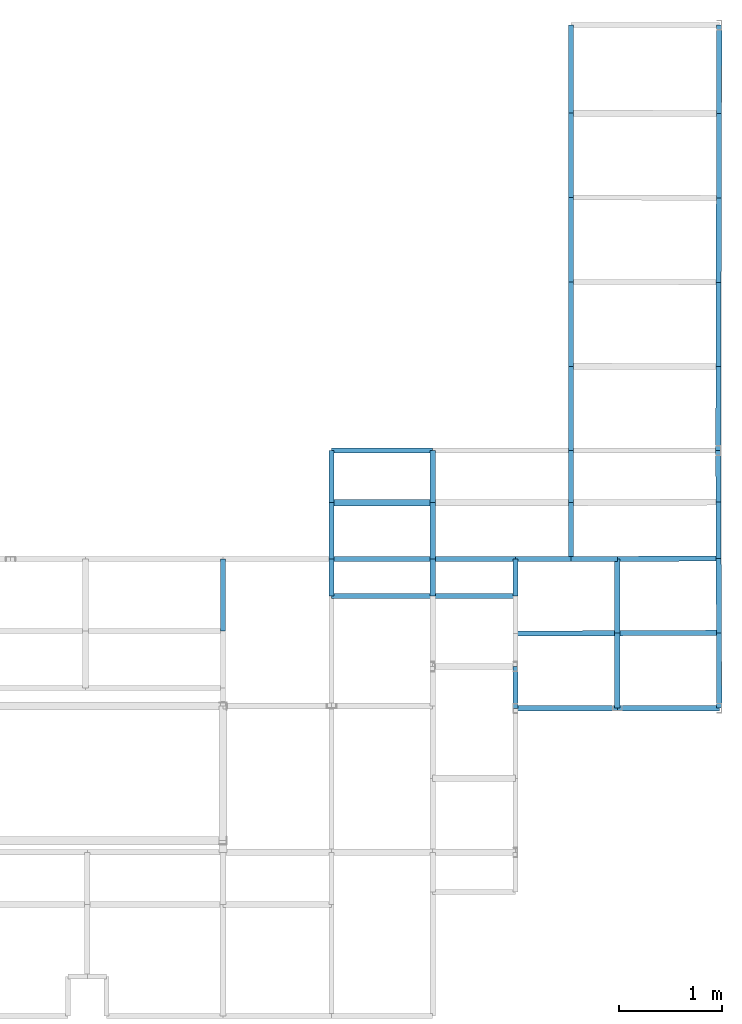
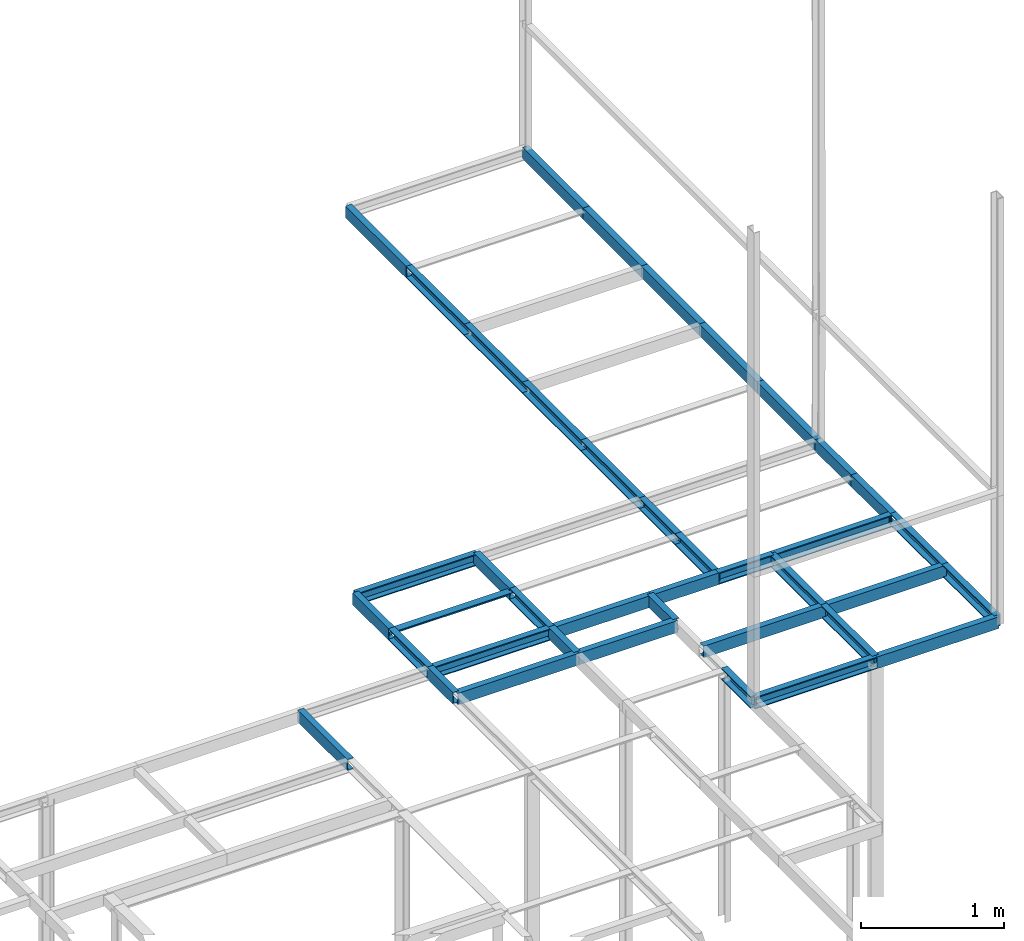
# Not in any storey, part 7 of 7: 40 beams.
"""IFC2X3 model written with IfcOpenShell, lengths in centimetres."""

import ifcopenshell
import ifcopenshell.guid

model = None  # the IFC model being written
_history = None  # IfcOwnerHistory: only IFC2X3 demands one
_inside = {}  # id of a spatial element -> (the spatial element, [elements in it])
_under = {}  # id of a project, library or spatial element -> (it, [spatial elements below it])
_declared = {}  # id of a project -> (the project, [libraries it declares])
_typed = {}  # id of a type object -> (the type object, [elements of that type])
_made_of = {}  # id of a material, layer set ... -> (it, [elements and type objects made of it])


def new_model(schema):
    """Start an empty IFC model of exactly this schema.

    Asked for "IFC4X3", IfcOpenShell would pick the latest addendum, in which some entities
    have other attributes; the version numbers below select the first issue.
    IFC2X3 requires an IfcOwnerHistory on every rooted entity: one is made here for all.
    """
    global model, _history
    if schema == "IFC4X3":
        model = ifcopenshell.file(schema_version=(4, 3, 0, 0))
    else:
        model = ifcopenshell.file(schema=schema)
    _inside.clear()
    _under.clear()
    _declared.clear()
    _typed.clear()
    _made_of.clear()
    _history = None
    if model.schema == "IFC2X3":
        org = make("IfcOrganization", Name="unknown")
        user = make(
            "IfcPersonAndOrganization",
            ThePerson=make("IfcPerson", FamilyName="unknown"),
            TheOrganization=org,
        )
        app = make(
            "IfcApplication",
            ApplicationDeveloper=org,
            Version="unknown",
            ApplicationFullName="unknown",
            ApplicationIdentifier="unknown",
        )
        _history = make(
            "IfcOwnerHistory",
            OwningUser=user,
            OwningApplication=app,
            ChangeAction="ADDED",
            CreationDate=0,
        )
    return model


def make(cls, **values):
    """One entity of the class cls with the attributes given. An attribute that is None is left unset."""
    return model.create_entity(
        cls, **{name: value for name, value in values.items() if value is not None}
    )


def rooted(cls, **values):
    """An entity with a GlobalId (a new one), such as an element, a storey or a relation."""
    return make(cls, GlobalId=ifcopenshell.guid.new(), OwnerHistory=_history, **values)


def si_unit(unit_type, name, prefix=None):
    """IfcSIUnit, for example si_unit("LENGTHUNIT", "METRE", prefix="MILLI")."""
    return make("IfcSIUnit", UnitType=unit_type, Prefix=prefix, Name=name)


def assignment(units):
    """IfcUnitAssignment: the units of a project."""
    return None if units is None else make("IfcUnitAssignment", Units=units)


def point(xyz):
    """IfcCartesianPoint."""
    return None if xyz is None else make("IfcCartesianPoint", Coordinates=xyz)


def direction(xyz):
    """IfcDirection."""
    return None if xyz is None else make("IfcDirection", DirectionRatios=xyz)


def frame(location, z_axis=None, x_axis=None):
    """IfcAxis2Placement3D, a coordinate frame: its origin and axes. An axis left out is left unset."""
    return make(
        "IfcAxis2Placement3D",
        Location=point(location),
        Axis=direction(z_axis),
        RefDirection=direction(x_axis),
    )


def frame_2d(location, x_axis=None):
    """IfcAxis2Placement2D, a coordinate frame in the plane: its origin and x axis."""
    return make(
        "IfcAxis2Placement2D", Location=point(location), RefDirection=direction(x_axis)
    )


def origin_with_axes():
    """The frame at (0, 0, 0) with the z axis (0, 0, 1) and the x axis (1, 0, 0) written out."""
    return frame((0.0, 0.0, 0.0), z_axis=(0.0, 0.0, 1.0), x_axis=(1.0, 0.0, 0.0))


def origin_2d_with_axis():
    """The frame at (0, 0) in the plane with the x axis (1, 0) written out."""
    return frame_2d((0.0, 0.0), x_axis=(1.0, 0.0))


def place(relative_to, where):
    """IfcLocalPlacement: puts the frame where relative to a parent placement (None: the world)."""
    return make(
        "IfcLocalPlacement", PlacementRelTo=relative_to, RelativePlacement=where
    )


def context(
    kind, dimensions, precision=None, world=None, true_north=None, identifier=None
):
    """IfcGeometricRepresentationContext, for example the 3D "Model" context."""
    return make(
        "IfcGeometricRepresentationContext",
        ContextIdentifier=identifier,
        ContextType=kind,
        CoordinateSpaceDimension=dimensions,
        Precision=precision,
        WorldCoordinateSystem=world,
        TrueNorth=true_north,
    )


def project(units=None, contexts=None):
    """IfcProject with its units and contexts."""
    return rooted(
        "IfcProject",
        Name="project",
        RepresentationContexts=contexts,
        UnitsInContext=assignment(units),
    )


def polyline(points):
    """IfcPolyline through the points."""
    return make("IfcPolyline", Points=[point(p) for p in points])


def profile(cls, at=None, kind="AREA", **sizes):
    """A parametric profile (cls). Its sizes go by their IFC names, for example OverallWidth=200.0."""
    return make(cls, ProfileType=kind, Position=at, **sizes)


def u_section(**sizes):
    """IfcUShapeProfileDef."""
    return profile("IfcUShapeProfileDef", **sizes)


def outline(outer, holes=None, kind="AREA"):
    """IfcArbitraryClosedProfileDef: a profile drawn as a closed curve; with holes, ...WithVoids."""
    if holes is None:
        return make("IfcArbitraryClosedProfileDef", ProfileType=kind, OuterCurve=outer)
    return make(
        "IfcArbitraryProfileDefWithVoids",
        ProfileType=kind,
        OuterCurve=outer,
        InnerCurves=holes,
    )


def extrude(swept, where, along, depth):
    """IfcExtrudedAreaSolid: the profile swept, set in the frame where, extruded along a direction by depth."""
    return make(
        "IfcExtrudedAreaSolid",
        SweptArea=swept,
        Position=where,
        ExtrudedDirection=direction(along),
        Depth=depth,
    )


def shape(context_of_items, identifier, shape_type, items):
    """IfcShapeRepresentation: the items that make up one representation, for example the "Body"."""
    return make(
        "IfcShapeRepresentation",
        ContextOfItems=context_of_items,
        RepresentationIdentifier=identifier,
        RepresentationType=shape_type,
        Items=items,
    )


def material(Name=None, Category=None):
    """IfcMaterial."""
    return make("IfcMaterial", Name=Name, Category=Category)


def made_of(thing, what):
    """Note that an element or type object is made of a material, layer set ...; save() writes the relation."""
    if what is not None:
        _made_of.setdefault(what.id(), (what, []))[1].append(thing)
    return thing


def element(
    cls,
    number,
    at=None,
    inside=None,
    cuts=None,
    type_object=None,
    material=None,
    context=None,
    identifier="Body",
    shape_type=None,
    held_by="IfcProductDefinitionShape",
    body=None,
    shapes=None,
    **own,
):
    """One element of the class cls, such as IfcWall. Its Tag is "e" and its number.

    at: its placement. inside: the storey or other place that contains it. cuts: it is an
    opening in that element (IfcRelVoidsElement). A single representation is given by context,
    identifier, shape_type and body (its items); several are given by shapes. held_by: the class
    of the entity that holds the representations. save() writes the other relations.
    """
    e = rooted(cls, Tag="e%d" % number, ObjectPlacement=at, **own)
    if body is not None:
        shapes = [shape(context, identifier, shape_type, body)]
    if shapes is not None:
        e.Representation = make(held_by, Representations=shapes)
    if inside is not None:
        _inside.setdefault(inside.id(), (inside, []))[1].append(e)
    if cuts is not None:
        rooted(
            "IfcRelVoidsElement", RelatingBuildingElement=cuts, RelatedOpeningElement=e
        )
    if type_object is not None:
        _typed.setdefault(type_object.id(), (type_object, []))[1].append(e)
    return made_of(e, material)


def aggregate(whole, parts):
    """IfcRelAggregates: a whole, such as a stair, and the parts it consists of."""
    return rooted("IfcRelAggregates", RelatingObject=whole, RelatedObjects=parts)


def save(model, path):
    """Write the relations noted so far, then the file.

    IfcRelAggregates (storeys below a building ...), IfcRelContainedInSpatialStructure (elements
    in a storey), IfcRelDefinesByType, IfcRelAssociatesMaterial and IfcRelDeclares: one each for
    every whole, place, type object, material and project.
    """
    for whole, parts in _under.values():
        aggregate(whole, parts)
    for where, things in _inside.values():
        rooted(
            "IfcRelContainedInSpatialStructure",
            RelatedElements=things,
            RelatingStructure=where,
        )
    for kind, things in _typed.values():
        rooted("IfcRelDefinesByType", RelatedObjects=things, RelatingType=kind)
    for what, things in _made_of.values():
        rooted("IfcRelAssociatesMaterial", RelatedObjects=things, RelatingMaterial=what)
    for by, libraries in _declared.values():
        rooted("IfcRelDeclares", RelatingContext=by, RelatedDefinitions=libraries)
    model.write(path)


model = new_model("IFC2X3")

# Units and contexts
model_context = context("Model", 3, precision=1e-05, world=origin_with_axes())
plan_context = context("Plan", 3, precision=1e-05, world=origin_with_axes())
ifc_project = project(units=[si_unit("LENGTHUNIT", "METRE", prefix="CENTI"), si_unit("AREAUNIT", "SQUARE_METRE", prefix="CENTI"), si_unit("VOLUMEUNIT", "CUBIC_METRE", prefix="CENTI"), si_unit("PLANEANGLEUNIT", "RADIAN"), si_unit("SOLIDANGLEUNIT", "STERADIAN"), si_unit("MASSUNIT", "GRAM"), si_unit("TIMEUNIT", "SECOND"), si_unit("THERMODYNAMICTEMPERATUREUNIT", "DEGREE_CELSIUS"), si_unit("LUMINOUSINTENSITYUNIT", "LUMEN")], contexts=[model_context, plan_context])

# Beams
ifc_material = material()
beam_1_placement = place(None, frame((345.100006103516, 706.5, 210.0), z_axis=(0.0, 1.0, 0.0), x_axis=(1.0, 0.0, 0.0)))
element("IfcBeam", 1, at=beam_1_placement, material=ifc_material, Name="UPN - de ala UPN 100", context=model_context, shape_type="SweptSolid", body=[
    extrude(u_section(Depth=10.0, FlangeWidth=5.0, WebThickness=0.6, FlangeThickness=0.85, FilletRadius=0.0, EdgeRadius=0.0, FlangeSlope=0.0, CentreOfGravityInX=0.0, at=origin_2d_with_axis()), origin_with_axes(), (0.0, 0.0, 1.0), 85.200012207031),
])
beam_2_placement = place(None, frame((488.300018310547, 706.200012207031, 210.0), z_axis=(0.00233896073, 0.999997264628, 0.0), x_axis=(0.999997258186, -0.002338960767, 0.0)))
element("IfcBeam", 2, at=beam_2_placement, material=ifc_material, Name="UPN - de ala UPN 100", context=model_context, shape_type="SweptSolid", body=[
    extrude(u_section(Depth=10.0, FlangeWidth=5.0, WebThickness=0.6, FlangeThickness=0.85, FilletRadius=0.0, EdgeRadius=0.0, FlangeSlope=0.0, CentreOfGravityInX=0.0, at=frame_2d((-4.42e-09, 0.0), x_axis=(1.0, 0.0))), origin_with_axes(), (0.0, 0.0, 1.0), 85.500233874979),
])
beam_3_placement = place(None, frame((345.100006103516, 624.900024414062, 210.0), z_axis=(0.0, 1.0, 0.0), x_axis=(-1.0, 0.0, 0.0)))
element("IfcBeam", 3, at=beam_3_placement, material=ifc_material, Name="UPN - de ala UPN 100", context=model_context, shape_type="SweptSolid", body=[
    extrude(u_section(Depth=10.0, FlangeWidth=5.0, WebThickness=0.6, FlangeThickness=0.85, FilletRadius=0.0, EdgeRadius=0.0, FlangeSlope=0.0, CentreOfGravityInX=0.0, at=origin_2d_with_axis()), origin_with_axes(), (0.0, 0.0, 1.0), 81.599975585938),
])
beam_4_placement = place(None, frame((488.100006103516, 624.5, 210.0), z_axis=(0.002448122127, 0.999997003345, 0.0), x_axis=(0.999997019768, -0.002448122017, 0.0)))
element("IfcBeam", 4, at=beam_4_placement, material=ifc_material, Name="UPN - de ala UPN 100", context=model_context, shape_type="SweptSolid", body=[
    extrude(u_section(Depth=10.0, FlangeWidth=5.0, WebThickness=0.6, FlangeThickness=0.85, FilletRadius=0.0, EdgeRadius=0.0, FlangeSlope=0.0, CentreOfGravityInX=0.0, at=frame_2d((1.2268e-08, 0.0), x_axis=(1.0, 0.0))), origin_with_axes(), (0.0, 0.0, 1.0), 81.700257034553),
])
beam_5_placement = place(None, frame((345.100006103516, 543.200012207031, 210.0), z_axis=(0.0, 1.0, 0.0), x_axis=(-1.0, 0.0, 0.0)))
element("IfcBeam", 5, at=beam_5_placement, material=ifc_material, Name="UPN - de ala UPN 100", context=model_context, shape_type="SweptSolid", body=[
    extrude(u_section(Depth=10.0, FlangeWidth=5.0, WebThickness=0.6, FlangeThickness=0.85, FilletRadius=0.0, EdgeRadius=0.0, FlangeSlope=0.0, CentreOfGravityInX=0.0, at=origin_2d_with_axis()), origin_with_axes(), (0.0, 0.0, 1.0), 81.700012207031),
])
beam_6_placement = place(None, frame((487.899993896484, 542.799987792969, 210.0), z_axis=(0.002448122127, 0.999997003345, 0.0), x_axis=(0.999997019768, -0.002448122017, 0.0)))
element("IfcBeam", 6, at=beam_6_placement, material=ifc_material, Name="UPN - de ala UPN 100", context=model_context, shape_type="SweptSolid", body=[
    extrude(u_section(Depth=10.0, FlangeWidth=5.0, WebThickness=0.6, FlangeThickness=0.85, FilletRadius=0.0, EdgeRadius=0.0, FlangeSlope=0.0, CentreOfGravityInX=0.0, at=frame_2d((1.2268e-08, 0.0), x_axis=(1.0, 0.0))), origin_with_axes(), (0.0, 0.0, 1.0), 81.700257034553),
])
beam_7_placement = place(None, frame((345.100006103516, 461.5, 210.0), z_axis=(0.0, 1.0, 0.0), x_axis=(-1.0, 0.0, 0.0)))
element("IfcBeam", 7, at=beam_7_placement, material=ifc_material, Name="UPN - de ala UPN 100", context=model_context, shape_type="SweptSolid", body=[
    extrude(u_section(Depth=10.0, FlangeWidth=5.0, WebThickness=0.6, FlangeThickness=0.85, FilletRadius=0.0, EdgeRadius=0.0, FlangeSlope=0.0, CentreOfGravityInX=0.0, at=origin_2d_with_axis()), origin_with_axes(), (0.0, 0.0, 1.0), 81.700012207031),
])
beam_8_placement = place(None, frame((487.700012207031, 461.200012207031, 210.0), z_axis=(0.002450749372, 0.999996996909, 0.0), x_axis=(0.999997019768, -0.002450749278, 0.0)))
element("IfcBeam", 8, at=beam_8_placement, material=ifc_material, Name="UPN - de ala UPN 100", context=model_context, shape_type="SweptSolid", body=[
    extrude(u_section(Depth=10.0, FlangeWidth=5.0, WebThickness=0.6, FlangeThickness=0.85, FilletRadius=0.0, EdgeRadius=0.0, FlangeSlope=0.0, CentreOfGravityInX=0.0, at=frame_2d((1.2204e-08, 0.0), x_axis=(1.0, 0.0))), origin_with_axes(), (0.0, 0.0, 1.0), 81.600220638805),
])
beam_9_placement = place(None, frame((345.100006103516, 379.800018310547, 210.0), z_axis=(0.0, 1.0, 0.0), x_axis=(-1.0, 0.0, 0.0)))
element("IfcBeam", 9, at=beam_9_placement, material=ifc_material, Name="UPN - de ala UPN 100", context=model_context, shape_type="SweptSolid", body=[
    extrude(u_section(Depth=10.0, FlangeWidth=5.0, WebThickness=0.6, FlangeThickness=0.85, FilletRadius=0.0, EdgeRadius=0.0, FlangeSlope=0.0, CentreOfGravityInX=0.0, at=origin_2d_with_axis()), origin_with_axes(), (0.0, 0.0, 1.0), 81.699981689453),
])
beam_10_placement = place(None, frame((487.5, 379.800018310547, 210.0), z_axis=(0.002457145187, 0.999996981214, 0.0), x_axis=(0.999996960163, -0.002457145136, 0.0)))
element("IfcBeam", 10, at=beam_10_placement, material=ifc_material, Name="UPN - de ala UPN 100", context=model_context, shape_type="SweptSolid", body=[
    extrude(u_section(Depth=10.0, FlangeWidth=5.0, WebThickness=0.6, FlangeThickness=0.85, FilletRadius=0.0, EdgeRadius=0.0, FlangeSlope=0.0, CentreOfGravityInX=0.0, at=frame_2d((-3.4e-11, 0.0), x_axis=(1.0, 0.0))), origin_with_axes(), (0.0, 0.0, 1.0), 81.400239626371),
])
beam_11_placement = place(None, frame((211.100006103516, 379.800018310547, 210.0), z_axis=(-1.0, 0.0, 0.0), x_axis=(0.0, -1.0, 0.0)))
element("IfcBeam", 11, at=beam_11_placement, material=ifc_material, Name="UPN - de ala UPN 100", context=model_context, shape_type="SweptSolid", body=[
    extrude(u_section(Depth=10.0, FlangeWidth=5.0, WebThickness=0.6, FlangeThickness=0.85, FilletRadius=0.0, EdgeRadius=0.0, FlangeSlope=0.0, CentreOfGravityInX=0.0, at=origin_2d_with_axis()), origin_with_axes(), (0.0, 0.0, 1.0), 98.000007629395),
])
for number, where, z_axis, x_axis, name in (
    (12, (113.099998474121, 329.399993896484, 210.0), (0.0, 1.0, 0.0), (1.0, 0.0, 0.0), "UPN - de ala UPN 100"),
    (13, (211.100006103516, 329.399993896484, 210.0), (0.0, 1.0, 0.0), (1.0, 0.0, 0.0), "UPN - de ala UPN 100"),
    (14, (345.100006103516, 329.399993896484, 210.0), (0.0, 1.0, 0.0), (-1.0, 0.0, 0.0), "UPN - de ala UPN 100"),
):
    element("IfcBeam", number, at=place(None, frame(where, z_axis=z_axis, x_axis=x_axis)), material=ifc_material, Name=name, context=model_context, shape_type="SweptSolid", body=[
        extrude(u_section(Depth=10.0, FlangeWidth=5.0, WebThickness=0.6, FlangeThickness=0.85, FilletRadius=0.0, EdgeRadius=0.0, FlangeSlope=0.0, CentreOfGravityInX=0.0, at=origin_2d_with_axis()), origin_with_axes(), (0.0, 0.0, 1.0), 50.400024414062),
    ])
beam_12_placement = place(None, frame((487.700012207031, 330.0, 210.0), z_axis=(-0.004016275509, 0.999991934733, 0.0), x_axis=(0.999991953373, 0.004016275518, 0.0)))
element("IfcBeam", 15, at=beam_12_placement, material=ifc_material, Name="UPN - de ala UPN 100", context=model_context, shape_type="SweptSolid", body=[
    extrude(u_section(Depth=10.0, FlangeWidth=5.0, WebThickness=0.6, FlangeThickness=0.85, FilletRadius=0.0, EdgeRadius=0.0, FlangeSlope=0.0, CentreOfGravityInX=0.0, at=frame_2d((-3.289e-09, 0.0), x_axis=(1.0, 0.0))), origin_with_axes(), (0.0, 0.0, 1.0), 49.800419964231),
])
beam_13_placement = place(None, frame((487.899993896484, 275.399993896484, 210.0), z_axis=(-0.003662643328, 0.999993292499, 0.0), x_axis=(0.999993264675, 0.003662643256, 0.0)))
element("IfcBeam", 16, at=beam_13_placement, material=ifc_material, Name="UPN - de ala UPN 100", context=model_context, shape_type="SweptSolid", body=[
    extrude(u_section(Depth=10.0, FlangeWidth=5.0, WebThickness=0.6, FlangeThickness=0.85, FilletRadius=0.0, EdgeRadius=0.0, FlangeSlope=0.0, CentreOfGravityInX=0.0, at=frame_2d((1.603e-09, 0.0), x_axis=(1.0, 0.0))), origin_with_axes(), (0.0, 0.0, 1.0), 54.600372335544),
])
beam_14_placement = place(None, frame((211.100006103516, 329.399993896484, 210.0), z_axis=(-1.0, 0.0, 0.0), x_axis=(0.0, 0.0, 1.0)))
element("IfcBeam", 17, at=beam_14_placement, material=ifc_material, context=model_context, shape_type="SweptSolid", body=[
    extrude(outline(polyline([(3.0, -3.0), (3.0, 3.0), (-3.0, 3.0), (-3.0, 2.5), (2.5, 2.5), (2.5, -3.0), (3.0, -3.0)])), origin_with_axes(), (0.0, 0.0, 1.0), 98.000007629395),
])
for number, where, z_axis, x_axis, name in (
    (18, (113.099998474121, 275.0, 210.0), (0.0, 1.0, 0.0), (-1.0, 0.0, 0.0), "UPN - de ala UPN 100"),
    (19, (211.100006103516, 275.0, 210.0), (0.0, 1.0, 0.0), (-1.0, 0.0, 0.0), "UPN - de ala UPN 100"),
    (20, (345.100006103516, 275.0, 210.0), (0.0, 1.0, 0.0), (-1.0, 0.0, 0.0), "UPN - de ala UPN 100"),
):
    element("IfcBeam", number, at=place(None, frame(where, z_axis=z_axis, x_axis=x_axis)), material=ifc_material, Name=name, context=model_context, shape_type="SweptSolid", body=[
        extrude(u_section(Depth=10.0, FlangeWidth=5.0, WebThickness=0.6, FlangeThickness=0.85, FilletRadius=0.0, EdgeRadius=0.0, FlangeSlope=0.0, CentreOfGravityInX=0.0, at=origin_2d_with_axis()), origin_with_axes(), (0.0, 0.0, 1.0), 54.399993896484),
    ])
beam_15_placement = place(None, frame((389.800018310547, 275.0, 210.0), z_axis=(0.999991687464, 0.004077376871, 0.0), x_axis=(0.004077376798, -0.999991714954, 0.0)))
element("IfcBeam", 21, at=beam_15_placement, material=ifc_material, Name="UPN - de ala UPN 100", context=model_context, shape_type="SweptSolid", body=[
    extrude(u_section(Depth=10.0, FlangeWidth=5.0, WebThickness=0.6, FlangeThickness=0.85, FilletRadius=0.0, EdgeRadius=0.0, FlangeSlope=0.0, CentreOfGravityInX=0.0, at=frame_2d((-1.8198e-08, 0.0), x_axis=(1.0, 0.0))), origin_with_axes(), (0.0, 0.0, 1.0), 98.100791052258),
])
beam_16_placement = place(None, frame((488.200012207031, 203.5, 210.0), z_axis=(-0.004172680447, 0.999991294331, 0.0), x_axis=(-0.999991297722, -0.004172680434, 0.0)))
element("IfcBeam", 22, at=beam_16_placement, material=ifc_material, Name="UPN - de ala UPN 100", context=model_context, shape_type="SweptSolid", body=[
    extrude(u_section(Depth=10.0, FlangeWidth=5.0, WebThickness=0.6, FlangeThickness=0.85, FilletRadius=0.0, EdgeRadius=0.0, FlangeSlope=0.0, CentreOfGravityInX=0.0, at=frame_2d((1.979e-09, 0.0), x_axis=(1.0, 0.0))), origin_with_axes(), (0.0, 0.0, 1.0), 71.900619839478),
])
beam_17_placement = place(None, frame((8.199999809265, 205.199996948242, 210.0), z_axis=(0.0, 1.0, 0.0), x_axis=(1.0, 0.0, 0.0)))
element("IfcBeam", 23, at=beam_17_placement, material=ifc_material, Name="UPN - de ala UPN 100", context=model_context, shape_type="SweptSolid", body=[
    extrude(u_section(Depth=10.0, FlangeWidth=5.0, WebThickness=0.6, FlangeThickness=0.85, FilletRadius=0.0, EdgeRadius=0.0, FlangeSlope=0.0, CentreOfGravityInX=0.0, at=frame_2d((2.38419e-07, 0.0), x_axis=(1.0, 0.0))), origin_with_axes(), (0.0, 0.0, 1.0), 69.800003051758),
])
beam_18_placement = place(None, frame((211.100006103516, 275.0, 210.0), z_axis=(-1.0, 0.0, 0.0), x_axis=(0.0, -1.0, 0.0)))
element("IfcBeam", 24, at=beam_18_placement, material=ifc_material, Name="UPN - de ala UPN 100", context=model_context, shape_type="SweptSolid", body=[
    extrude(u_section(Depth=10.0, FlangeWidth=5.0, WebThickness=0.6, FlangeThickness=0.85, FilletRadius=0.0, EdgeRadius=0.0, FlangeSlope=0.0, CentreOfGravityInX=0.0, at=origin_2d_with_axis()), origin_with_axes(), (0.0, 0.0, 1.0), 98.000007629395),
])
beam_19_placement = place(None, frame((113.099998474121, 239.0, 210.0), z_axis=(0.0, 1.0, 0.0), x_axis=(1.0, 0.0, 0.0)))
element("IfcBeam", 25, at=beam_19_placement, material=ifc_material, Name="UPN - de ala UPN 100", context=model_context, shape_type="SweptSolid", body=[
    extrude(u_section(Depth=10.0, FlangeWidth=5.0, WebThickness=0.6, FlangeThickness=0.85, FilletRadius=0.0, EdgeRadius=0.0, FlangeSlope=0.0, CentreOfGravityInX=0.0, at=origin_2d_with_axis()), origin_with_axes(), (0.0, 0.0, 1.0), 36.0),
])
beam_20_placement = place(None, frame((291.100006103516, 275.0, 210.0), z_axis=(-1.0, 0.0, 0.0), x_axis=(0.0, 1.0, 0.0)))
element("IfcBeam", 26, at=beam_20_placement, material=ifc_material, Name="UPN - de ala UPN 100", context=model_context, shape_type="SweptSolid", body=[
    extrude(u_section(Depth=10.0, FlangeWidth=5.0, WebThickness=0.6, FlangeThickness=0.85, FilletRadius=0.0, EdgeRadius=0.0, FlangeSlope=0.0, CentreOfGravityInX=0.0, at=origin_2d_with_axis()), origin_with_axes(), (0.0, 0.0, 1.0), 80.0),
])
beam_21_placement = place(None, frame((211.100006103516, 239.0, 210.0), z_axis=(0.0, 1.0, 0.0), x_axis=(1.0, 0.0, 0.0)))
element("IfcBeam", 27, at=beam_21_placement, material=ifc_material, Name="UPN - de ala UPN 100", context=model_context, shape_type="SweptSolid", body=[
    extrude(u_section(Depth=10.0, FlangeWidth=5.0, WebThickness=0.6, FlangeThickness=0.85, FilletRadius=0.0, EdgeRadius=0.0, FlangeSlope=0.0, CentreOfGravityInX=0.0, at=origin_2d_with_axis()), origin_with_axes(), (0.0, 0.0, 1.0), 36.0),
])
beam_22_placement = place(None, frame((345.100006103516, 275.0, 210.0), z_axis=(-1.0, 0.0, 0.0), x_axis=(0.0, 1.0, 0.0)))
element("IfcBeam", 28, at=beam_22_placement, material=ifc_material, Name="UPN - de ala UPN 100", context=model_context, shape_type="SweptSolid", body=[
    extrude(u_section(Depth=10.0, FlangeWidth=5.0, WebThickness=0.6, FlangeThickness=0.85, FilletRadius=0.0, EdgeRadius=0.0, FlangeSlope=0.0, CentreOfGravityInX=0.0, at=origin_2d_with_axis()), origin_with_axes(), (0.0, 0.0, 1.0), 54.0),
])
beam_23_placement = place(None, frame((291.100006103516, 239.0, 210.0), z_axis=(0.0, 1.0, 0.0), x_axis=(1.0, 0.0, 0.0)))
element("IfcBeam", 29, at=beam_23_placement, material=ifc_material, Name="UPN - de ala UPN 100", context=model_context, shape_type="SweptSolid", body=[
    extrude(u_section(Depth=10.0, FlangeWidth=5.0, WebThickness=0.6, FlangeThickness=0.85, FilletRadius=0.0, EdgeRadius=0.0, FlangeSlope=0.0, CentreOfGravityInX=0.0, at=origin_2d_with_axis()), origin_with_axes(), (0.0, 0.0, 1.0), 36.0),
])
beam_24_placement = place(None, frame((389.800018310547, 275.0, 210.0), z_axis=(-1.0, 0.0, 0.0), x_axis=(0.0, -1.0, 0.0)))
element("IfcBeam", 30, at=beam_24_placement, material=ifc_material, Name="UPN - de ala UPN 100", context=model_context, shape_type="SweptSolid", body=[
    extrude(u_section(Depth=10.0, FlangeWidth=5.0, WebThickness=0.6, FlangeThickness=0.85, FilletRadius=0.0, EdgeRadius=0.0, FlangeSlope=0.0, CentreOfGravityInX=0.0, at=origin_2d_with_axis()), origin_with_axes(), (0.0, 0.0, 1.0), 44.700012207031),
])
beam_25_placement = place(None, frame((389.800018310547, 203.100006103516, 210.0), z_axis=(0.0, 1.0, 0.0), x_axis=(-1.0, 0.0, 0.0)))
element("IfcBeam", 31, at=beam_25_placement, material=ifc_material, Name="UPN - de ala UPN 100", context=model_context, shape_type="SweptSolid", body=[
    extrude(u_section(Depth=10.0, FlangeWidth=5.0, WebThickness=0.6, FlangeThickness=0.85, FilletRadius=0.0, EdgeRadius=0.0, FlangeSlope=0.0, CentreOfGravityInX=0.0, at=origin_2d_with_axis()), origin_with_axes(), (0.0, 0.0, 1.0), 71.899993896484),
])
beam_26_placement = place(None, frame((211.100006103516, 239.0, 210.0), z_axis=(-1.0, 0.0, 0.0), x_axis=(0.0, 1.0, 0.0)))
element("IfcBeam", 32, at=beam_26_placement, material=ifc_material, Name="UPN - de ala UPN 100", context=model_context, shape_type="SweptSolid", body=[
    extrude(u_section(Depth=10.0, FlangeWidth=5.0, WebThickness=0.6, FlangeThickness=0.85, FilletRadius=0.0, EdgeRadius=0.0, FlangeSlope=0.0, CentreOfGravityInX=0.0, at=origin_2d_with_axis()), origin_with_axes(), (0.0, 0.0, 1.0), 98.000007629395),
])
beam_27_placement = place(None, frame((291.100006103516, 239.0, 210.0), z_axis=(-1.0, 0.0, 0.0), x_axis=(0.0, 1.0, 0.0)))
element("IfcBeam", 33, at=beam_27_placement, material=ifc_material, Name="UPN - de ala UPN 100", context=model_context, shape_type="SweptSolid", body=[
    extrude(u_section(Depth=10.0, FlangeWidth=5.0, WebThickness=0.6, FlangeThickness=0.85, FilletRadius=0.0, EdgeRadius=0.0, FlangeSlope=0.0, CentreOfGravityInX=0.0, at=origin_2d_with_axis()), origin_with_axes(), (0.0, 0.0, 1.0), 80.0),
])
beam_28_placement = place(None, frame((389.800018310547, 203.100006103516, 210.0), z_axis=(0.999991738076, 0.00406494529, 0.0), x_axis=(-0.004064945504, 0.999991714954, 0.0)))
element("IfcBeam", 34, at=beam_28_placement, material=ifc_material, Name="UPN - de ala UPN 100", context=model_context, shape_type="SweptSolid", body=[
    extrude(u_section(Depth=10.0, FlangeWidth=5.0, WebThickness=0.6, FlangeThickness=0.85, FilletRadius=0.0, EdgeRadius=0.0, FlangeSlope=0.0, CentreOfGravityInX=0.0, at=frame_2d((-3.0273e-08, 0.0), x_axis=(1.0, 0.0))), origin_with_axes(), (0.0, 0.0, 1.0), 98.400806876496),
])
beam_29_placement = place(None, frame((488.5, 130.5, 210.0), z_axis=(-0.004109387123, 0.999991556433, 0.0), x_axis=(-0.99999153614, -0.004109387286, 0.0)))
element("IfcBeam", 35, at=beam_29_placement, material=ifc_material, Name="UPN - de ala UPN 100", context=model_context, shape_type="SweptSolid", body=[
    extrude(u_section(Depth=10.0, FlangeWidth=5.0, WebThickness=0.6, FlangeThickness=0.85, FilletRadius=0.0, EdgeRadius=0.0, FlangeSlope=0.0, CentreOfGravityInX=0.0, at=frame_2d((-1.7964e-08, 0.0), x_axis=(1.0, 0.0))), origin_with_axes(), (0.0, 0.0, 1.0), 73.000616385589),
])
beam_30_placement = place(None, frame((291.100006103516, 202.699996948242, 210.0), z_axis=(0.9999917876, 0.004052743878, 0.0), x_axis=(-0.004052743781, 0.999991774559, 0.0)))
element("IfcBeam", 36, at=beam_30_placement, material=ifc_material, Name="UPN - de ala UPN 100", context=model_context, shape_type="SweptSolid", body=[
    extrude(u_section(Depth=10.0, FlangeWidth=5.0, WebThickness=0.6, FlangeThickness=0.85, FilletRadius=0.0, EdgeRadius=0.0, FlangeSlope=0.0, CentreOfGravityInX=0.0, at=frame_2d((4.33e-09, 0.0), x_axis=(1.0, 0.0))), origin_with_axes(), (0.0, 0.0, 1.0), 98.700822777687),
])
beam_31_placement = place(None, frame((389.800018310547, 130.5, 210.0), z_axis=(0.0, 1.0, 0.0), x_axis=(-1.0, 0.0, 0.0)))
element("IfcBeam", 37, at=beam_31_placement, material=ifc_material, Name="UPN - de ala UPN 100", context=model_context, shape_type="SweptSolid", body=[
    extrude(u_section(Depth=10.0, FlangeWidth=5.0, WebThickness=0.6, FlangeThickness=0.85, FilletRadius=0.0, EdgeRadius=0.0, FlangeSlope=0.0, CentreOfGravityInX=0.0, at=origin_2d_with_axis()), origin_with_axes(), (0.0, 0.0, 1.0), 72.600006103516),
])
beam_32_placement = place(None, frame((291.100006103516, 130.400009155273, 210.0), z_axis=(0.0, 1.0, 0.0), x_axis=(-1.0, 0.0, 0.0)))
element("IfcBeam", 38, at=beam_32_placement, material=ifc_material, Name="UPN - de ala UPN 100", context=model_context, shape_type="SweptSolid", body=[
    extrude(u_section(Depth=10.0, FlangeWidth=5.0, WebThickness=0.6, FlangeThickness=0.85, FilletRadius=0.0, EdgeRadius=0.0, FlangeSlope=0.0, CentreOfGravityInX=0.0, at=origin_2d_with_axis()), origin_with_axes(), (0.0, 0.0, 1.0), 40.599990844727),
])
beam_33_placement = place(None, frame((488.5, 130.5, 210.0), z_axis=(-1.0, 0.0, 0.0), x_axis=(0.0, 1.0, 0.0)))
element("IfcBeam", 39, at=beam_33_placement, material=ifc_material, Name="UPN - de ala UPN 100", context=model_context, shape_type="SweptSolid", body=[
    extrude(u_section(Depth=10.0, FlangeWidth=5.0, WebThickness=0.6, FlangeThickness=0.85, FilletRadius=0.0, EdgeRadius=0.0, FlangeSlope=0.0, CentreOfGravityInX=0.0, at=origin_2d_with_axis()), origin_with_axes(), (0.0, 0.0, 1.0), 98.699981689453),
])
beam_34_placement = place(None, frame((291.100006103516, 130.400009155273, 210.0), z_axis=(0.999999486837, 0.001013077822, 0.0), x_axis=(0.001013077796, -0.999999463558, 0.0)))
element("IfcBeam", 40, at=beam_34_placement, material=ifc_material, Name="UPN - de ala UPN 100", context=model_context, shape_type="SweptSolid", body=[
    extrude(u_section(Depth=10.0, FlangeWidth=5.0, WebThickness=0.6, FlangeThickness=0.85, FilletRadius=0.0, EdgeRadius=0.0, FlangeSlope=0.0, CentreOfGravityInX=0.0, at=frame_2d((-3.04e-10, 0.0), x_axis=(1.0, 0.0))), origin_with_axes(), (0.0, 0.0, 1.0), 98.700062856298),
])

save(model, "model.ifc")
